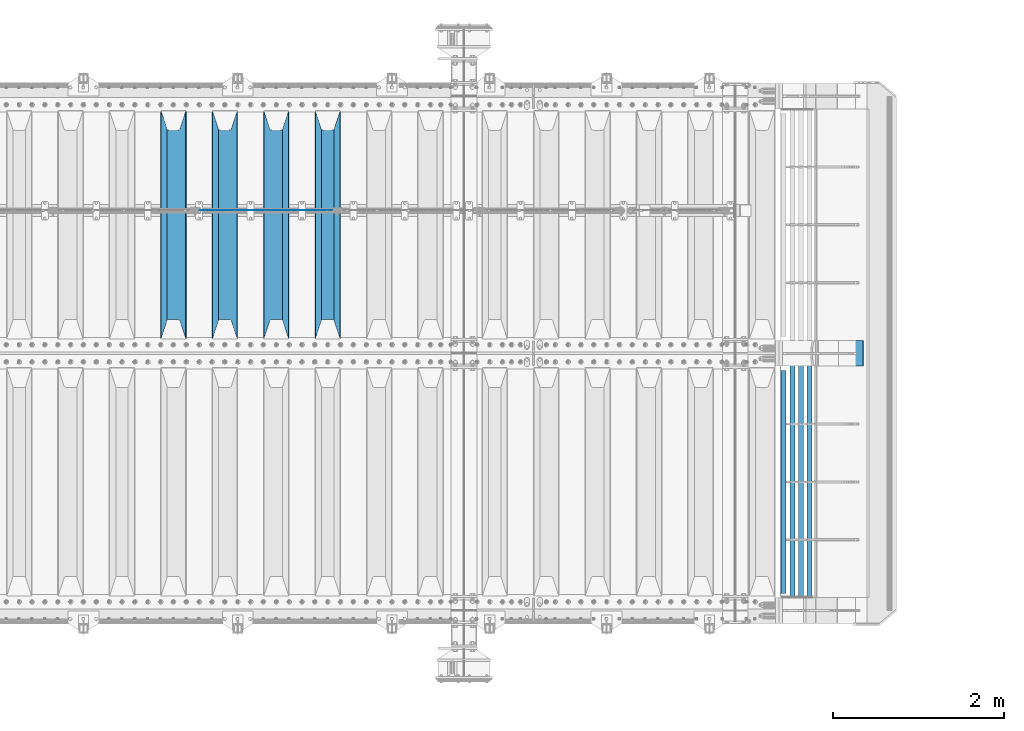
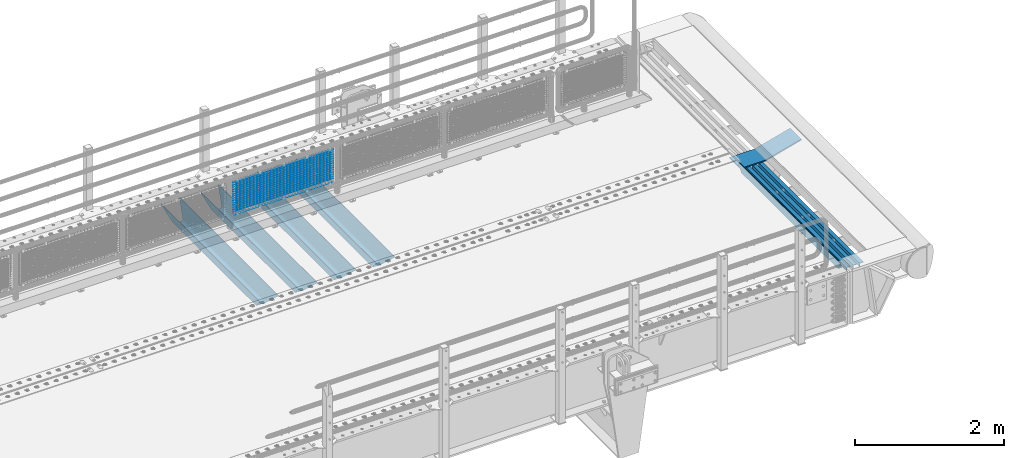
# One storey, part 97 of 193: 24 beams.
"""IFC2X3 building model written with IfcOpenShell, lengths in millimetres."""

from ifc_helpers import new_model, si_unit, frame, origin_with_axes, place, context, subcontext, project, spatial, faceted_brep, material, type_object, element, save


model = new_model("IFC2X3")

# Units and contexts
model_context = context("Model", 3, precision=1e-05, world=origin_with_axes())
body_context = subcontext(model_context, "Body", "Model", "MODEL_VIEW")
ifc_project = project(units=[si_unit("LENGTHUNIT", "METRE", prefix="MILLI"), si_unit("AREAUNIT", "SQUARE_METRE"), si_unit("VOLUMEUNIT", "CUBIC_METRE"), si_unit("MASSUNIT", "GRAM", prefix="KILO"), si_unit("TIMEUNIT", "SECOND"), si_unit("PLANEANGLEUNIT", "RADIAN"), si_unit("SOLIDANGLEUNIT", "STERADIAN"), si_unit("THERMODYNAMICTEMPERATUREUNIT", "DEGREE_CELSIUS"), si_unit("LUMINOUSINTENSITYUNIT", "LUMEN")], contexts=[model_context])

# Site, building, storey
site_placement = place(None, origin_with_axes())
site = spatial("IfcSite", under=ifc_project, at=site_placement, CompositionType="ELEMENT")
building_placement = place(site_placement, origin_with_axes())
building = spatial("IfcBuilding", under=site, at=building_placement, Name="Standard", CompositionType="ELEMENT")
storey_placement = place(building_placement, origin_with_axes())
storey = spatial("IfcBuildingStorey", under=building, at=storey_placement, Name="Undefined", CompositionType="ELEMENT", Elevation=0.0)

# Beams
ifc_material_1 = material(Name="STEEL/S355N")
beam_type_1 = type_object("IfcBeamType", PredefinedType="NOTDEFINED")
beam_1_placement = place(storey_placement, frame((-33650.0, 27175.0, -115.0), z_axis=(0.0, 0.0, 1.0), x_axis=(0.0, 1.0, 0.0)))
element("IfcBeam", 1, at=beam_1_placement, inside=storey, type_object=beam_type_1, material=ifc_material_1, context=body_context, shape_type="Brep", body=[
    faceted_brep([(0.0, 150.0, 115.0), (0.0, 143.689999999999, 115.0), (2650.00000000297, 143.689999999999, 115.0), (2650.00000000297, 150.0, 115.0), (2650.00000000297, 142.059565218398, 110.000000003094), (2650.00000000297, 148.3695652184, 110.000000003094), (2441.90079219209, -80.1103600731112, -98.0992078077845), (2437.7588105432, -77.5672621345584, -102.241189456673), (2434.06523489747, -74.4080125315522, -105.934765102404), (2430.9108609509, -70.710272125576, -109.089139048974), (2428.37322971128, -66.5649389910068, -111.626770288588), (2426.51472138055, -62.0739139532889, -113.485278619323), (2425.38102192092, -57.3475956567672, -114.618978078955), (2424.99999999988, -52.5021667386536, -115.0), (2424.99999999988, 52.5021667386536, -115.0), (2425.38102192092, 57.3475956567672, -114.618978078955), (2426.51472138055, 62.0739139532889, -113.485278619323), (2428.37322971128, 66.5649389910068, -111.626770288588), (2430.9108609509, 70.710272125576, -109.089139048974), (2434.06523489747, 74.4080125315522, -105.934765102404), (2437.7588105432, 77.5672621345584, -102.241189456673), (2441.90079219209, 80.1103600731112, -98.0992078077846), (2446.38936140512, 81.9747917625791, -93.6106385947584), (2448.2494850041, 76.2713538057251, -91.7505149957729), (2444.62967112263, 74.76777986261, -95.3703288772456), (2441.28936334127, 72.7168944282894, -98.710636658607), (2438.31067330439, 70.1691124903846, -101.689326695487), (2435.76682334748, 67.1870637758839, -104.233176652398), (2433.72034654134, 63.8440531834895, -106.279653458539), (2432.22154950042, 60.222258798236, -107.778450499454), (2431.30727574265, 56.4107117849089, -108.692724257221), (2430.99999999987, 52.5031078186876, -109.0), (2430.99999999987, -52.5031078186876, -109.0), (2431.30727574265, -56.4107117849089, -108.692724257221), (2432.22154950042, -60.222258798236, -107.778450499454), (2433.72034654134, -63.8440531834895, -106.279653458539), (2435.76682334748, -67.1870637758839, -104.233176652398), (2438.31067330439, -70.1691124903846, -101.689326695487), (2441.28936334127, -72.7168944282894, -98.7106366586071), (2444.62967112263, -74.76777986261, -95.3703288772457), (2448.2494850041, -76.2713538057251, -91.7505149957729), (2650.00000000297, -142.059565218398, 110.000000003094), (2650.00000000297, -148.3695652184, 110.000000003094), (2446.38936140512, -81.9747917625791, -93.6106385947584), (2650.00000000297, -143.689999999999, 115.0), (2650.00000000297, -150.0, 115.0), (0.0, -143.689999999999, 115.0), (0.0, -150.0, 115.0), (0.0, -148.369565218261, 110.000000002667), (203.610638597427, -81.9747917625791, -93.6106385947584), (208.099207810446, -80.1103600731112, -98.0992078077845), (212.241189459342, -77.5672621345584, -102.241189456673), (215.93476510507, -74.4080125315522, -105.934765102404), (219.089139051641, -70.710272125576, -109.089139048974), (221.626770291256, -66.5649389910068, -111.626770288588), (223.485278621989, -62.0739139532889, -113.485278619323), (224.618978081624, -57.3475956567672, -114.618978078955), (225.000000002663, -52.5021667386536, -115.0), (225.000000002663, 52.5021667386536, -115.0), (224.618978081624, 57.3475956567672, -114.618978078955), (223.485278621989, 62.0739139532889, -113.485278619323), (221.626770291256, 66.5649389910068, -111.626770288588), (219.089139051641, 70.710272125576, -109.089139048974), (215.93476510507, 74.4080125315522, -105.934765102404), (212.241189459342, 77.5672621345584, -102.241189456673), (208.099207810446, 80.1103600731112, -98.0992078077846), (203.610638597427, 81.9747917625791, -93.6106385947584), (0.0, 148.369565218261, 110.000000002667), (0.0, 142.05956521826, 110.000000002667), (201.750514998439, 76.2713538057251, -91.7505149957729), (205.370328879915, 74.76777986261, -95.3703288772456), (208.710636661275, 72.7168944282894, -98.710636658607), (211.689326698157, 70.1691124903846, -101.689326695487), (214.233176655063, 67.1870637758839, -104.233176652398), (216.279653461206, 63.8440531834895, -106.279653458539), (217.778450502123, 60.222258798236, -107.778450499454), (218.69272425989, 56.4107117849089, -108.692724257221), (219.00000000267, 52.5031078186876, -109.0), (219.00000000267, -52.5031078186876, -109.0), (218.69272425989, -56.4107117849089, -108.692724257221), (217.778450502123, -60.222258798236, -107.778450499454), (216.279653461206, -63.8440531834895, -106.279653458539), (214.233176655063, -67.1870637758839, -104.233176652398), (211.689326698157, -70.1691124903846, -101.689326695487), (208.710636661275, -72.7168944282894, -98.7106366586071), (205.370328879915, -74.76777986261, -95.3703288772457), (201.750514998439, -76.2713538057251, -91.7505149957729), (0.0, -142.05956521826, 110.000000002667)], [[[0, 1, 2, 3]], [[3, 2, 4, 5]], [[6, 7, 8, 9, 10, 11, 12, 13, 14, 15, 16, 17, 18, 19, 20, 21, 22, 5, 4, 23, 24, 25, 26, 27, 28, 29, 30, 31, 32, 33, 34, 35, 36, 37, 38, 39, 40, 41, 42, 43]], [[44, 45, 42, 41]], [[46, 47, 45, 44]], [[43, 42, 45, 47, 48, 49]], [[6, 43, 49, 50]], [[7, 6, 50, 51]], [[8, 7, 51, 52]], [[9, 8, 52, 53]], [[10, 9, 53, 54]], [[11, 10, 54, 55]], [[12, 11, 55, 56]], [[13, 12, 56, 57]], [[14, 13, 57, 58]], [[15, 14, 58, 59]], [[16, 15, 59, 60]], [[17, 16, 60, 61]], [[18, 17, 61, 62]], [[19, 18, 62, 63]], [[20, 19, 63, 64]], [[21, 20, 64, 65]], [[22, 21, 65, 66]], [[0, 3, 5, 22, 66, 67]], [[1, 0, 67, 68]], [[23, 4, 2, 1, 68, 69]], [[24, 23, 69, 70]], [[25, 24, 70, 71]], [[26, 25, 71, 72]], [[27, 26, 72, 73]], [[28, 27, 73, 74]], [[29, 28, 74, 75]], [[30, 29, 75, 76]], [[31, 30, 76, 77]], [[32, 31, 77, 78]], [[33, 32, 78, 79]], [[34, 33, 79, 80]], [[35, 34, 80, 81]], [[36, 35, 81, 82]], [[37, 36, 82, 83]], [[38, 37, 83, 84]], [[39, 38, 84, 85]], [[40, 39, 85, 86]], [[46, 44, 41, 40, 86, 87]], [[47, 46, 87, 48]], [[86, 85, 84, 83, 82, 81, 80, 79, 78, 77, 76, 75, 74, 73, 72, 71, 70, 69, 68, 67, 66, 65, 64, 63, 62, 61, 60, 59, 58, 57, 56, 55, 54, 53, 52, 51, 50, 49, 48, 87]]]),
])
beam_2_placement = place(storey_placement, frame((-34250.0, 27175.0, -115.0), z_axis=(0.0, 0.0, 1.0), x_axis=(0.0, 1.0, 0.0)))
element("IfcBeam", 2, at=beam_2_placement, inside=storey, type_object=beam_type_1, material=ifc_material_1, context=body_context, shape_type="Brep", body=[
    faceted_brep([(0.0, 150.0, 115.0), (0.0, 143.689999999999, 115.0), (2650.00000000297, 143.689999999999, 115.0), (2650.00000000297, 150.0, 115.0), (2650.00000000297, 142.059565218398, 110.000000003094), (2650.00000000297, 148.3695652184, 110.000000003094), (2441.90079219209, -80.1103600731112, -98.0992078077845), (2437.7588105432, -77.5672621345584, -102.241189456673), (2434.06523489747, -74.4080125315522, -105.934765102404), (2430.9108609509, -70.710272125576, -109.089139048974), (2428.37322971128, -66.5649389910068, -111.626770288588), (2426.51472138055, -62.0739139532889, -113.485278619323), (2425.38102192092, -57.3475956567672, -114.618978078955), (2424.99999999988, -52.5021667386536, -115.0), (2424.99999999988, 52.5021667386536, -115.0), (2425.38102192092, 57.3475956567672, -114.618978078955), (2426.51472138055, 62.0739139532889, -113.485278619323), (2428.37322971128, 66.5649389910068, -111.626770288588), (2430.9108609509, 70.710272125576, -109.089139048974), (2434.06523489747, 74.4080125315522, -105.934765102404), (2437.7588105432, 77.5672621345584, -102.241189456673), (2441.90079219209, 80.1103600731112, -98.0992078077846), (2446.38936140512, 81.9747917625791, -93.6106385947584), (2448.2494850041, 76.2713538057251, -91.7505149957729), (2444.62967112263, 74.76777986261, -95.3703288772456), (2441.28936334127, 72.7168944282894, -98.710636658607), (2438.31067330439, 70.1691124903846, -101.689326695487), (2435.76682334748, 67.1870637758839, -104.233176652398), (2433.72034654134, 63.8440531834895, -106.279653458539), (2432.22154950042, 60.222258798236, -107.778450499454), (2431.30727574265, 56.4107117849089, -108.692724257221), (2430.99999999987, 52.5031078186876, -109.0), (2430.99999999987, -52.5031078186876, -109.0), (2431.30727574265, -56.4107117849089, -108.692724257221), (2432.22154950042, -60.222258798236, -107.778450499454), (2433.72034654134, -63.8440531834895, -106.279653458539), (2435.76682334748, -67.1870637758839, -104.233176652398), (2438.31067330439, -70.1691124903846, -101.689326695487), (2441.28936334127, -72.7168944282894, -98.7106366586071), (2444.62967112263, -74.76777986261, -95.3703288772457), (2448.2494850041, -76.2713538057251, -91.7505149957729), (2650.00000000297, -142.059565218398, 110.000000003094), (2650.00000000297, -148.3695652184, 110.000000003094), (2446.38936140512, -81.9747917625791, -93.6106385947584), (2650.00000000297, -143.689999999999, 115.0), (2650.00000000297, -150.0, 115.0), (0.0, -143.689999999999, 115.0), (0.0, -150.0, 115.0), (0.0, -148.369565218261, 110.000000002667), (203.610638597427, -81.9747917625791, -93.6106385947584), (208.099207810446, -80.1103600731112, -98.0992078077845), (212.241189459342, -77.5672621345584, -102.241189456673), (215.93476510507, -74.4080125315522, -105.934765102404), (219.089139051641, -70.710272125576, -109.089139048974), (221.626770291256, -66.5649389910068, -111.626770288588), (223.485278621989, -62.0739139532889, -113.485278619323), (224.618978081624, -57.3475956567672, -114.618978078955), (225.000000002663, -52.5021667386536, -115.0), (225.000000002663, 52.5021667386536, -115.0), (224.618978081624, 57.3475956567672, -114.618978078955), (223.485278621989, 62.0739139532889, -113.485278619323), (221.626770291256, 66.5649389910068, -111.626770288588), (219.089139051641, 70.710272125576, -109.089139048974), (215.93476510507, 74.4080125315522, -105.934765102404), (212.241189459342, 77.5672621345584, -102.241189456673), (208.099207810446, 80.1103600731112, -98.0992078077846), (203.610638597427, 81.9747917625791, -93.6106385947584), (0.0, 148.369565218261, 110.000000002667), (0.0, 142.05956521826, 110.000000002667), (201.750514998439, 76.2713538057251, -91.7505149957729), (205.370328879915, 74.76777986261, -95.3703288772456), (208.710636661275, 72.7168944282894, -98.710636658607), (211.689326698157, 70.1691124903846, -101.689326695487), (214.233176655063, 67.1870637758839, -104.233176652398), (216.279653461206, 63.8440531834895, -106.279653458539), (217.778450502123, 60.222258798236, -107.778450499454), (218.69272425989, 56.4107117849089, -108.692724257221), (219.00000000267, 52.5031078186876, -109.0), (219.00000000267, -52.5031078186876, -109.0), (218.69272425989, -56.4107117849089, -108.692724257221), (217.778450502123, -60.222258798236, -107.778450499454), (216.279653461206, -63.8440531834895, -106.279653458539), (214.233176655063, -67.1870637758839, -104.233176652398), (211.689326698157, -70.1691124903846, -101.689326695487), (208.710636661275, -72.7168944282894, -98.7106366586071), (205.370328879915, -74.76777986261, -95.3703288772457), (201.750514998439, -76.2713538057251, -91.7505149957729), (0.0, -142.05956521826, 110.000000002667)], [[[0, 1, 2, 3]], [[3, 2, 4, 5]], [[6, 7, 8, 9, 10, 11, 12, 13, 14, 15, 16, 17, 18, 19, 20, 21, 22, 5, 4, 23, 24, 25, 26, 27, 28, 29, 30, 31, 32, 33, 34, 35, 36, 37, 38, 39, 40, 41, 42, 43]], [[44, 45, 42, 41]], [[46, 47, 45, 44]], [[43, 42, 45, 47, 48, 49]], [[6, 43, 49, 50]], [[7, 6, 50, 51]], [[8, 7, 51, 52]], [[9, 8, 52, 53]], [[10, 9, 53, 54]], [[11, 10, 54, 55]], [[12, 11, 55, 56]], [[13, 12, 56, 57]], [[14, 13, 57, 58]], [[15, 14, 58, 59]], [[16, 15, 59, 60]], [[17, 16, 60, 61]], [[18, 17, 61, 62]], [[19, 18, 62, 63]], [[20, 19, 63, 64]], [[21, 20, 64, 65]], [[22, 21, 65, 66]], [[0, 3, 5, 22, 66, 67]], [[1, 0, 67, 68]], [[23, 4, 2, 1, 68, 69]], [[24, 23, 69, 70]], [[25, 24, 70, 71]], [[26, 25, 71, 72]], [[27, 26, 72, 73]], [[28, 27, 73, 74]], [[29, 28, 74, 75]], [[30, 29, 75, 76]], [[31, 30, 76, 77]], [[32, 31, 77, 78]], [[33, 32, 78, 79]], [[34, 33, 79, 80]], [[35, 34, 80, 81]], [[36, 35, 81, 82]], [[37, 36, 82, 83]], [[38, 37, 83, 84]], [[39, 38, 84, 85]], [[40, 39, 85, 86]], [[46, 44, 41, 40, 86, 87]], [[47, 46, 87, 48]], [[86, 85, 84, 83, 82, 81, 80, 79, 78, 77, 76, 75, 74, 73, 72, 71, 70, 69, 68, 67, 66, 65, 64, 63, 62, 61, 60, 59, 58, 57, 56, 55, 54, 53, 52, 51, 50, 49, 48, 87]]]),
])
beam_3_placement = place(storey_placement, frame((-34850.0, 27175.0, -115.0), z_axis=(0.0, 0.0, 1.0), x_axis=(0.0, 1.0, 0.0)))
element("IfcBeam", 3, at=beam_3_placement, inside=storey, type_object=beam_type_1, material=ifc_material_1, context=body_context, shape_type="Brep", body=[
    faceted_brep([(0.0, 150.0, 115.0), (0.0, 143.689999999999, 115.0), (2650.00000000297, 143.689999999999, 115.0), (2650.00000000297, 150.0, 115.0), (2650.00000000297, 142.059565218398, 110.000000003094), (2650.00000000297, 148.3695652184, 110.000000003094), (2441.90079219209, -80.1103600731112, -98.0992078077845), (2437.7588105432, -77.5672621345584, -102.241189456673), (2434.06523489747, -74.4080125315522, -105.934765102404), (2430.9108609509, -70.710272125576, -109.089139048974), (2428.37322971128, -66.5649389910068, -111.626770288588), (2426.51472138055, -62.0739139532889, -113.485278619323), (2425.38102192092, -57.3475956567672, -114.618978078955), (2424.99999999988, -52.5021667386536, -115.0), (2424.99999999988, 52.5021667386536, -115.0), (2425.38102192092, 57.3475956567672, -114.618978078955), (2426.51472138055, 62.0739139532889, -113.485278619323), (2428.37322971128, 66.5649389910068, -111.626770288588), (2430.9108609509, 70.710272125576, -109.089139048974), (2434.06523489747, 74.4080125315522, -105.934765102404), (2437.7588105432, 77.5672621345584, -102.241189456673), (2441.90079219209, 80.1103600731112, -98.0992078077846), (2446.38936140512, 81.9747917625791, -93.6106385947584), (2448.2494850041, 76.2713538057251, -91.7505149957729), (2444.62967112263, 74.76777986261, -95.3703288772456), (2441.28936334127, 72.7168944282894, -98.710636658607), (2438.31067330439, 70.1691124903846, -101.689326695487), (2435.76682334748, 67.1870637758839, -104.233176652398), (2433.72034654134, 63.8440531834895, -106.279653458539), (2432.22154950042, 60.222258798236, -107.778450499454), (2431.30727574265, 56.4107117849089, -108.692724257221), (2430.99999999987, 52.5031078186876, -109.0), (2430.99999999987, -52.5031078186876, -109.0), (2431.30727574265, -56.4107117849089, -108.692724257221), (2432.22154950042, -60.222258798236, -107.778450499454), (2433.72034654134, -63.8440531834895, -106.279653458539), (2435.76682334748, -67.1870637758839, -104.233176652398), (2438.31067330439, -70.1691124903846, -101.689326695487), (2441.28936334127, -72.7168944282894, -98.7106366586071), (2444.62967112263, -74.76777986261, -95.3703288772457), (2448.2494850041, -76.2713538057251, -91.7505149957729), (2650.00000000297, -142.059565218398, 110.000000003094), (2650.00000000297, -148.3695652184, 110.000000003094), (2446.38936140512, -81.9747917625791, -93.6106385947584), (2650.00000000297, -143.689999999999, 115.0), (2650.00000000297, -150.0, 115.0), (0.0, -143.689999999999, 115.0), (0.0, -150.0, 115.0), (0.0, -148.369565218261, 110.000000002667), (203.610638597427, -81.9747917625791, -93.6106385947584), (208.099207810446, -80.1103600731112, -98.0992078077845), (212.241189459342, -77.5672621345584, -102.241189456673), (215.93476510507, -74.4080125315522, -105.934765102404), (219.089139051641, -70.710272125576, -109.089139048974), (221.626770291256, -66.5649389910068, -111.626770288588), (223.485278621989, -62.0739139532889, -113.485278619323), (224.618978081624, -57.3475956567672, -114.618978078955), (225.000000002663, -52.5021667386536, -115.0), (225.000000002663, 52.5021667386536, -115.0), (224.618978081624, 57.3475956567672, -114.618978078955), (223.485278621989, 62.0739139532889, -113.485278619323), (221.626770291256, 66.5649389910068, -111.626770288588), (219.089139051641, 70.710272125576, -109.089139048974), (215.93476510507, 74.4080125315522, -105.934765102404), (212.241189459342, 77.5672621345584, -102.241189456673), (208.099207810446, 80.1103600731112, -98.0992078077846), (203.610638597427, 81.9747917625791, -93.6106385947584), (0.0, 148.369565218261, 110.000000002667), (0.0, 142.05956521826, 110.000000002667), (201.750514998439, 76.2713538057251, -91.7505149957729), (205.370328879915, 74.76777986261, -95.3703288772456), (208.710636661275, 72.7168944282894, -98.710636658607), (211.689326698157, 70.1691124903846, -101.689326695487), (214.233176655063, 67.1870637758839, -104.233176652398), (216.279653461206, 63.8440531834895, -106.279653458539), (217.778450502123, 60.222258798236, -107.778450499454), (218.69272425989, 56.4107117849089, -108.692724257221), (219.00000000267, 52.5031078186876, -109.0), (219.00000000267, -52.5031078186876, -109.0), (218.69272425989, -56.4107117849089, -108.692724257221), (217.778450502123, -60.222258798236, -107.778450499454), (216.279653461206, -63.8440531834895, -106.279653458539), (214.233176655063, -67.1870637758839, -104.233176652398), (211.689326698157, -70.1691124903846, -101.689326695487), (208.710636661275, -72.7168944282894, -98.7106366586071), (205.370328879915, -74.76777986261, -95.3703288772457), (201.750514998439, -76.2713538057251, -91.7505149957729), (0.0, -142.05956521826, 110.000000002667)], [[[0, 1, 2, 3]], [[3, 2, 4, 5]], [[6, 7, 8, 9, 10, 11, 12, 13, 14, 15, 16, 17, 18, 19, 20, 21, 22, 5, 4, 23, 24, 25, 26, 27, 28, 29, 30, 31, 32, 33, 34, 35, 36, 37, 38, 39, 40, 41, 42, 43]], [[44, 45, 42, 41]], [[46, 47, 45, 44]], [[43, 42, 45, 47, 48, 49]], [[6, 43, 49, 50]], [[7, 6, 50, 51]], [[8, 7, 51, 52]], [[9, 8, 52, 53]], [[10, 9, 53, 54]], [[11, 10, 54, 55]], [[12, 11, 55, 56]], [[13, 12, 56, 57]], [[14, 13, 57, 58]], [[15, 14, 58, 59]], [[16, 15, 59, 60]], [[17, 16, 60, 61]], [[18, 17, 61, 62]], [[19, 18, 62, 63]], [[20, 19, 63, 64]], [[21, 20, 64, 65]], [[22, 21, 65, 66]], [[0, 3, 5, 22, 66, 67]], [[1, 0, 67, 68]], [[23, 4, 2, 1, 68, 69]], [[24, 23, 69, 70]], [[25, 24, 70, 71]], [[26, 25, 71, 72]], [[27, 26, 72, 73]], [[28, 27, 73, 74]], [[29, 28, 74, 75]], [[30, 29, 75, 76]], [[31, 30, 76, 77]], [[32, 31, 77, 78]], [[33, 32, 78, 79]], [[34, 33, 79, 80]], [[35, 34, 80, 81]], [[36, 35, 81, 82]], [[37, 36, 82, 83]], [[38, 37, 83, 84]], [[39, 38, 84, 85]], [[40, 39, 85, 86]], [[46, 44, 41, 40, 86, 87]], [[47, 46, 87, 48]], [[86, 85, 84, 83, 82, 81, 80, 79, 78, 77, 76, 75, 74, 73, 72, 71, 70, 69, 68, 67, 66, 65, 64, 63, 62, 61, 60, 59, 58, 57, 56, 55, 54, 53, 52, 51, 50, 49, 48, 87]]]),
])
beam_4_placement = place(storey_placement, frame((-35450.0, 27175.0, -115.0), z_axis=(0.0, 0.0, 1.0), x_axis=(0.0, 1.0, 0.0)))
element("IfcBeam", 4, at=beam_4_placement, inside=storey, type_object=beam_type_1, material=ifc_material_1, context=body_context, shape_type="Brep", body=[
    faceted_brep([(0.0, 150.0, 115.0), (0.0, 143.689999999999, 115.0), (2650.00000000297, 143.689999999999, 115.0), (2650.00000000297, 150.0, 115.0), (2650.00000000297, 142.059565218398, 110.000000003094), (2650.00000000297, 148.3695652184, 110.000000003094), (2441.90079219209, -80.1103600731112, -98.0992078077845), (2437.7588105432, -77.5672621345584, -102.241189456673), (2434.06523489747, -74.4080125315522, -105.934765102404), (2430.9108609509, -70.710272125576, -109.089139048974), (2428.37322971128, -66.5649389910068, -111.626770288588), (2426.51472138055, -62.0739139532889, -113.485278619323), (2425.38102192092, -57.3475956567672, -114.618978078955), (2424.99999999988, -52.5021667386536, -115.0), (2424.99999999988, 52.5021667386536, -115.0), (2425.38102192092, 57.3475956567672, -114.618978078955), (2426.51472138055, 62.0739139532889, -113.485278619323), (2428.37322971128, 66.5649389910068, -111.626770288588), (2430.9108609509, 70.710272125576, -109.089139048974), (2434.06523489747, 74.4080125315522, -105.934765102404), (2437.7588105432, 77.5672621345584, -102.241189456673), (2441.90079219209, 80.1103600731112, -98.0992078077846), (2446.38936140512, 81.9747917625791, -93.6106385947584), (2448.2494850041, 76.2713538057251, -91.7505149957729), (2444.62967112263, 74.76777986261, -95.3703288772456), (2441.28936334127, 72.7168944282894, -98.710636658607), (2438.31067330439, 70.1691124903846, -101.689326695487), (2435.76682334748, 67.1870637758839, -104.233176652398), (2433.72034654134, 63.8440531834895, -106.279653458539), (2432.22154950042, 60.222258798236, -107.778450499454), (2431.30727574265, 56.4107117849089, -108.692724257221), (2430.99999999987, 52.5031078186876, -109.0), (2430.99999999987, -52.5031078186876, -109.0), (2431.30727574265, -56.4107117849089, -108.692724257221), (2432.22154950042, -60.222258798236, -107.778450499454), (2433.72034654134, -63.8440531834895, -106.279653458539), (2435.76682334748, -67.1870637758839, -104.233176652398), (2438.31067330439, -70.1691124903846, -101.689326695487), (2441.28936334127, -72.7168944282894, -98.7106366586071), (2444.62967112263, -74.76777986261, -95.3703288772457), (2448.2494850041, -76.2713538057251, -91.7505149957729), (2650.00000000297, -142.059565218398, 110.000000003094), (2650.00000000297, -148.3695652184, 110.000000003094), (2446.38936140512, -81.9747917625791, -93.6106385947584), (2650.00000000297, -143.689999999999, 115.0), (2650.00000000297, -150.0, 115.0), (0.0, -143.689999999999, 115.0), (0.0, -150.0, 115.0), (0.0, -148.369565218261, 110.000000002667), (203.610638597427, -81.9747917625791, -93.6106385947584), (208.099207810446, -80.1103600731112, -98.0992078077845), (212.241189459342, -77.5672621345584, -102.241189456673), (215.93476510507, -74.4080125315522, -105.934765102404), (219.089139051641, -70.710272125576, -109.089139048974), (221.626770291256, -66.5649389910068, -111.626770288588), (223.485278621989, -62.0739139532889, -113.485278619323), (224.618978081624, -57.3475956567672, -114.618978078955), (225.000000002663, -52.5021667386536, -115.0), (225.000000002663, 52.5021667386536, -115.0), (224.618978081624, 57.3475956567672, -114.618978078955), (223.485278621989, 62.0739139532889, -113.485278619323), (221.626770291256, 66.5649389910068, -111.626770288588), (219.089139051641, 70.710272125576, -109.089139048974), (215.93476510507, 74.4080125315522, -105.934765102404), (212.241189459342, 77.5672621345584, -102.241189456673), (208.099207810446, 80.1103600731112, -98.0992078077846), (203.610638597427, 81.9747917625791, -93.6106385947584), (0.0, 148.369565218261, 110.000000002667), (0.0, 142.05956521826, 110.000000002667), (201.750514998439, 76.2713538057251, -91.7505149957729), (205.370328879915, 74.76777986261, -95.3703288772456), (208.710636661275, 72.7168944282894, -98.710636658607), (211.689326698157, 70.1691124903846, -101.689326695487), (214.233176655063, 67.1870637758839, -104.233176652398), (216.279653461206, 63.8440531834895, -106.279653458539), (217.778450502123, 60.222258798236, -107.778450499454), (218.69272425989, 56.4107117849089, -108.692724257221), (219.00000000267, 52.5031078186876, -109.0), (219.00000000267, -52.5031078186876, -109.0), (218.69272425989, -56.4107117849089, -108.692724257221), (217.778450502123, -60.222258798236, -107.778450499454), (216.279653461206, -63.8440531834895, -106.279653458539), (214.233176655063, -67.1870637758839, -104.233176652398), (211.689326698157, -70.1691124903846, -101.689326695487), (208.710636661275, -72.7168944282894, -98.7106366586071), (205.370328879915, -74.76777986261, -95.3703288772457), (201.750514998439, -76.2713538057251, -91.7505149957729), (0.0, -142.05956521826, 110.000000002667)], [[[0, 1, 2, 3]], [[3, 2, 4, 5]], [[6, 7, 8, 9, 10, 11, 12, 13, 14, 15, 16, 17, 18, 19, 20, 21, 22, 5, 4, 23, 24, 25, 26, 27, 28, 29, 30, 31, 32, 33, 34, 35, 36, 37, 38, 39, 40, 41, 42, 43]], [[44, 45, 42, 41]], [[46, 47, 45, 44]], [[43, 42, 45, 47, 48, 49]], [[6, 43, 49, 50]], [[7, 6, 50, 51]], [[8, 7, 51, 52]], [[9, 8, 52, 53]], [[10, 9, 53, 54]], [[11, 10, 54, 55]], [[12, 11, 55, 56]], [[13, 12, 56, 57]], [[14, 13, 57, 58]], [[15, 14, 58, 59]], [[16, 15, 59, 60]], [[17, 16, 60, 61]], [[18, 17, 61, 62]], [[19, 18, 62, 63]], [[20, 19, 63, 64]], [[21, 20, 64, 65]], [[22, 21, 65, 66]], [[0, 3, 5, 22, 66, 67]], [[1, 0, 67, 68]], [[23, 4, 2, 1, 68, 69]], [[24, 23, 69, 70]], [[25, 24, 70, 71]], [[26, 25, 71, 72]], [[27, 26, 72, 73]], [[28, 27, 73, 74]], [[29, 28, 74, 75]], [[30, 29, 75, 76]], [[31, 30, 76, 77]], [[32, 31, 77, 78]], [[33, 32, 78, 79]], [[34, 33, 79, 80]], [[35, 34, 80, 81]], [[36, 35, 81, 82]], [[37, 36, 82, 83]], [[38, 37, 83, 84]], [[39, 38, 84, 85]], [[40, 39, 85, 86]], [[46, 44, 41, 40, 86, 87]], [[47, 46, 87, 48]], [[86, 85, 84, 83, 82, 81, 80, 79, 78, 77, 76, 75, 74, 73, 72, 71, 70, 69, 68, 67, 66, 65, 64, 63, 62, 61, 60, 59, 58, 57, 56, 55, 54, 53, 52, 51, 50, 49, 48, 87]]]),
])
ifc_material_2 = material(Name="STEEL/S355J2")
beam_type_2 = type_object("IfcBeamType", PredefinedType="NOTDEFINED")
beam_5_placement = place(storey_placement, frame((-28335.4974739935, 24150.0, -124.999999999985), z_axis=(0.0, 0.0, 1.0), x_axis=(0.0, 1.0, 0.0)))
element("IfcBeam", 5, at=beam_5_placement, inside=storey, type_object=beam_type_2, material=ifc_material_2, context=body_context, shape_type="Brep", body=[
    faceted_brep([(2700.0, 22.5, -15.0), (2684.54915028125, 22.5000000000036, -17.4471741852423), (2684.54915028125, 32.5000000000036, -17.4471741852423), (2700.0, 32.5, -15.0), (2670.61073738538, 22.5000000000036, -24.5491502812526), (2670.61073738538, 32.5000000000036, -24.5491502812526), (2659.54915028125, 22.5000000000036, -35.6107373853764), (2659.54915028125, 32.5000000000036, -35.6107373853764), (2652.44717418524, 22.5000000000036, -49.5491502812526), (2652.44717418524, 32.5000000000036, -49.5491502812526), (2651.58384440325, -32.5, -55.0), (2650.0, -32.5, -65.0), (2650.0, 32.5, -65.0), (2651.58384440325, 22.5, -55.0), (0.0, 32.5, 65.0), (0.0, 22.5, 65.0), (2700.0, 22.5, 65.0), (2700.0, 32.5, 65.0), (0.0, 32.5, -15.0), (0.0, 22.5, -15.0), (15.4508497187489, 32.5, -17.4471741852423), (15.4508497187489, 22.5, -17.4471741852423), (29.3892626146226, 32.5, -24.5491502812526), (29.3892626146226, 22.5, -24.5491502812526), (40.4508497187489, 32.5, -35.6107373853764), (40.4508497187489, 22.5, -35.6107373853764), (47.5528258147569, 32.5, -49.5491502812526), (47.5528258147569, 22.5, -49.5491502812526), (50.0, -32.5, -65.0), (48.4161555967548, -32.5, -55.0), (48.4161555967548, 22.5, -55.0), (50.0, 32.5, -65.0)], [[[0, 1, 2, 3]], [[4, 5, 2, 1]], [[6, 7, 5, 4]], [[8, 9, 7, 6]], [[10, 11, 12, 9, 8, 13]], [[14, 15, 16, 17]], [[15, 14, 18, 19]], [[19, 18, 20, 21]], [[21, 20, 22, 23]], [[23, 22, 24, 25]], [[25, 24, 26, 27]], [[28, 29, 30, 27, 26, 31]], [[30, 29, 10, 13]], [[16, 15, 19, 21, 23, 25, 27, 30, 13, 8, 6, 4, 1, 0]], [[17, 16, 0, 3]], [[5, 7, 9, 12, 31, 26, 24, 22, 20, 18, 14, 17, 3, 2]], [[28, 31, 12, 11]], [[29, 28, 11, 10]]]),
])
beam_type_3 = type_object("IfcBeamType", PredefinedType="NOTDEFINED")
for number, where, z_axis, x_axis in (
    (6, (-28027.9975852833, 26869.9999976591, -210.000211453654), (0.0, 0.0, -1.0), (0.0, -1.0, 0.0)),
    (7, (-28127.9975852833, 26869.9999976591, -210.000211453654), (0.0, 0.0, -1.0), (0.0, -1.0, 0.0)),
    (8, (-28227.997585284, 26869.9999976591, -210.000211453713), (0.0, 0.0, -1.0), (0.0, -1.0, 0.0)),
):
    element("IfcBeam", number, at=place(storey_placement, frame(where, z_axis=z_axis, x_axis=x_axis)), inside=storey, type_object=beam_type_3, material=ifc_material_2, context=body_context, shape_type="Brep", body=[
        faceted_brep([(3.63797880709171e-12, 30.0000000000036, -30.0), (0.0, 30.0000000000036, 30.0), (2710.00000000001, 30.0000000000036, 30.0), (2710.00000000001, 30.0000000000036, -30.0), (0.0, 24.0000000000036, 30.0), (2710.00000000001, 24.0000000000036, 30.0), (0.0, 24.0000000000036, -24.0), (2710.00000000001, 24.0000000000036, -24.0), (3.63797880709171e-12, -29.9999999999964, -24.0), (2710.00000000001, -29.9999999999964, -24.0), (3.63797880709171e-12, -29.9999999999964, -30.0), (2710.00000000001, -29.9999999999964, -30.0)], [[[0, 1, 2, 3]], [[1, 4, 5, 2]], [[4, 6, 7, 5]], [[6, 8, 9, 7]], [[8, 10, 11, 9]], [[10, 0, 3, 11]], [[5, 7, 9, 11, 3, 2]], [[10, 8, 6, 4, 1, 0]]]),
    ])
ifc_material_3 = material(Name="Misc_Undefined")
beam_type_4 = type_object("IfcBeamType", Name="D3", PredefinedType="NOTDEFINED")
for number, where, z_axis, x_axis in (
    (9, (-35142.0, 28670.5, 851.597), (0.0, 0.0, 1.0), (1.0, 0.0, 0.0)),
    (10, (-35142.0, 28670.5, 669.452000000001), (0.0, 0.0, 1.0), (1.0, 0.0, 0.0)),
    (11, (-35142.0, 28670.5, 523.736000000001), (0.0, 0.0, 1.0), (1.0, 0.0, 0.0)),
    (12, (-35142.0, 28670.5, 487.307000000001), (0.0, 0.0, 1.0), (1.0, 0.0, 0.0)),
    (13, (-35142.0, 28670.5, 705.881000000001), (0.0, 0.0, 1.0), (1.0, 0.0, 0.0)),
    (14, (-35142.0, 28670.5, 596.594000000001), (0.0, 0.0, 1.0), (1.0, 0.0, 0.0)),
    (15, (-35142.0, 28670.5, 450.878000000001), (0.0, 0.0, 1.0), (1.0, 0.0, 0.0)),
    (16, (-35142.0, 28670.5, 815.168000000001), (0.0, 0.0, 1.0), (1.0, 0.0, 0.0)),
    (17, (-35142.0, 28670.5, 888.026000000001), (0.0, 0.0, 1.0), (1.0, 0.0, 0.0)),
    (18, (-35142.0, 28670.5, 778.739000000001), (0.0, 0.0, 1.0), (1.0, 0.0, 0.0)),
    (19, (-35142.0, 28670.5, 742.310000000001), (0.0, 0.0, 1.0), (1.0, 0.0, 0.0)),
    (20, (-35142.0, 28670.5, 633.023000000001), (0.0, 0.0, 1.0), (1.0, 0.0, 0.0)),
    (21, (-35142.0, 28670.5, 560.165000000001), (0.0, 0.0, 1.0), (1.0, 0.0, 0.0)),
    (22, (-35142.0, 28670.5, 414.449000000001), (0.0, 0.0, 1.0), (1.0, 0.0, 0.0)),
):
    element("IfcBeam", number, at=place(storey_placement, frame(where, z_axis=z_axis, x_axis=x_axis)), inside=storey, type_object=beam_type_4, material=ifc_material_3, ObjectType="D3", context=body_context, shape_type="Brep", body=[
        faceted_brep([(0.0, -1.49999999999636, 3.63797880709171e-12), (0.0, -0.75, -1.29903810567669), (1548.0, -0.75, -1.29903810567669), (1548.0, -1.5, 0.0), (0.0, 0.75, -1.29903810567669), (1548.0, 0.75, -1.29903810567669), (0.0, 1.50000000000364, 7.27595761418343e-12), (1548.0, 1.5, 0.0), (0.0, 0.75, 1.29903810567669), (1548.0, 0.75, 1.29903810567669), (0.0, -0.75, 1.29903810567669), (1548.0, -0.75, 1.29903810567669)], [[[0, 1, 2, 3]], [[1, 4, 5, 2]], [[4, 6, 7, 5]], [[6, 8, 9, 7]], [[8, 10, 11, 9]], [[10, 0, 3, 11]], [[5, 7, 9, 11, 3, 2]], [[10, 8, 6, 4, 1, 0]]]),
    ])
beam_6_placement = place(storey_placement, frame((-35117.0, 28670.5, 353.020000000001), z_axis=(0.0, 0.0, 1.0), x_axis=(1.0, 0.0, 0.0)))
element("IfcBeam", 23, at=beam_6_placement, inside=storey, type_object=beam_type_4, material=ifc_material_3, ObjectType="D3", context=body_context, shape_type="Brep", body=[
    faceted_brep([(0.0, -1.49999999999636, 3.63797880709171e-12), (0.0, -0.75, -1.29903810567669), (1498.0, -0.75, -1.29903810567669), (1498.0, -1.5, 0.0), (0.0, 0.75, -1.29903810567669), (1498.0, 0.75, -1.29903810567663), (0.0, 1.50000000000364, 7.27595761418343e-12), (1498.0, 1.5, 0.0), (0.0, 0.75, 1.29903810567669), (1498.0, 0.75, 1.29903810567669), (0.0, -0.75, 1.29903810567669), (1498.0, -0.75, 1.29903810567669)], [[[0, 1, 2, 3]], [[1, 4, 5, 2]], [[4, 6, 7, 5]], [[6, 8, 9, 7]], [[8, 10, 11, 9]], [[10, 0, 3, 11]], [[5, 7, 9, 11, 3, 2]], [[10, 8, 6, 4, 1, 0]]]),
])
beam_type_5 = type_object("IfcBeamType", PredefinedType="NOTDEFINED")
beam_7_placement = place(storey_placement, frame((-28343.0011701094, 27000.0, -169.999999999995), z_axis=(0.0, -1.0, 0.0), x_axis=(1.0, 0.0, 0.0)))
element("IfcBeam", 24, at=beam_7_placement, inside=storey, type_object=beam_type_5, material=ifc_material_1, context=body_context, shape_type="Brep", body=[
    faceted_brep([(0.0, 10.0, -150.0), (0.0, 10.0, 150.0), (356.495387467741, 10.0, 150.0), (356.495387467749, 9.99999999999858, -150.0), (0.0, -10.0, 150.0), (0.0, -10.0, -150.0), (356.495387467741, -10.0, -150.0), (356.495387467741, -10.0, 150.0), (382.770279632416, 11.7334369044538, 150.0), (382.770279632416, 11.7334369044538, -150.0), (385.397768848896, -8.09321940509972, -150.0), (385.397768848896, -8.09321940509972, 150.0), (413.799145684919, -2.40593045895696, -150.0), (413.799145684919, -2.40593045895696, 150.0), (408.589713119687, 16.9036995827633, 150.0), (408.589713119891, 16.9036995827009, -150.0), (939.000000000015, 160.0, 150.0), (939.000000000015, 160.0, -150.0), (944.209432565229, 140.69036995827, 150.0), (944.209432565229, 140.69036995827, -150.0)], [[[0, 1, 2, 3]], [[4, 5, 6, 7]], [[5, 4, 1, 0]], [[3, 2, 8, 9]], [[7, 6, 10, 11]], [[10, 12, 13, 11]], [[8, 14, 15, 9]], [[15, 14, 16, 17]], [[14, 8, 2, 1, 4, 7, 11, 13, 18, 16]], [[13, 12, 19, 18]], [[12, 10, 6, 5, 0, 3, 9, 15, 17, 19]], [[18, 19, 17, 16]]]),
])

save(model, "model.ifc")
